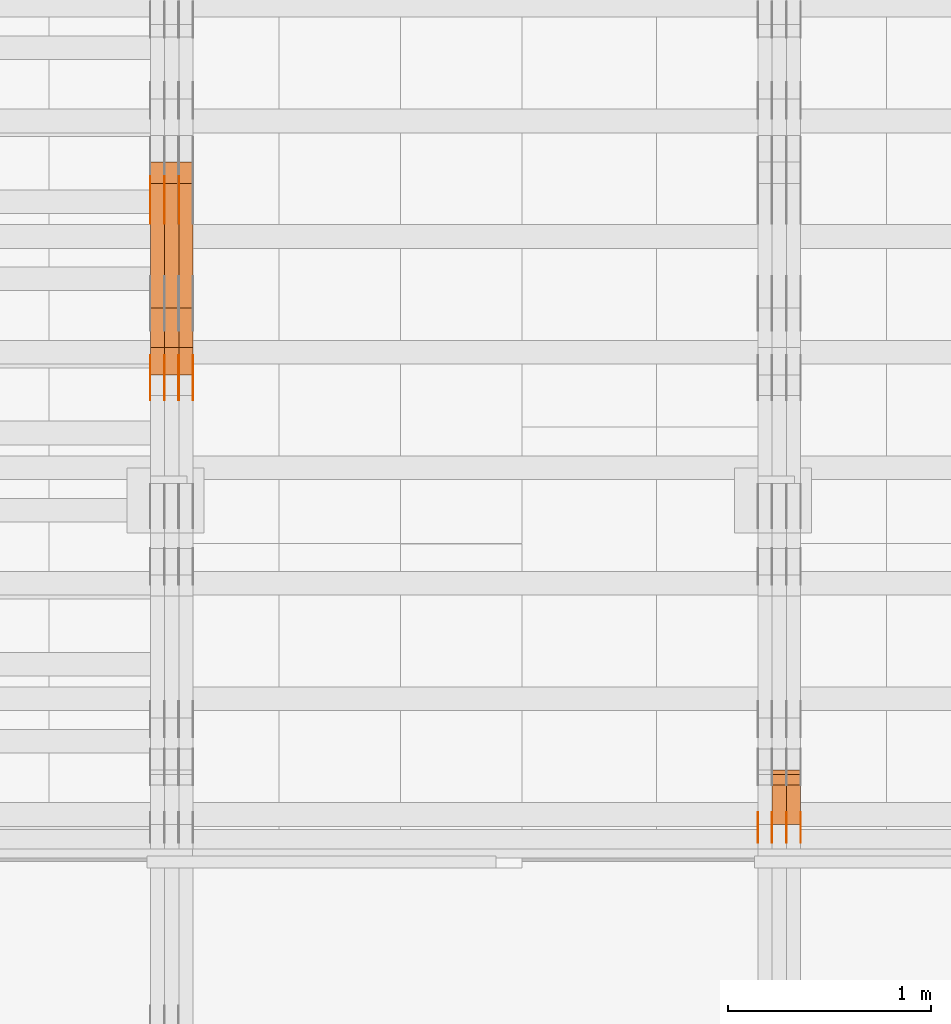
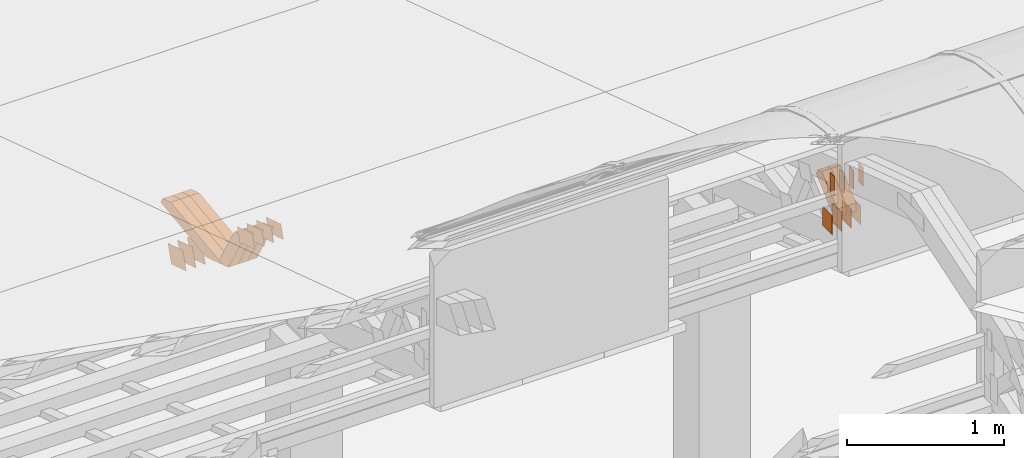
# One storey, part 87 of 385: 30 proxies.
"""IFC2X3 building model written with IfcOpenShell, lengths in millimetres."""

from ifc_helpers import new_model, entity, si_unit, converted_unit, derived_unit, direction, frame, origin, origin_2d_with_axis, place, context, subcontext, project, spatial, polyline, rectangle, outline, extrude, source, transform, mapped, material, type_object, type_shapes, element, save


model = new_model("IFC2X3")

# Units and contexts
model_context = context("Model", 3, precision=0.01, world=origin(), true_north=direction((6.12303176911189e-17, 1.0)))
body_context = subcontext(model_context, "Body", "Model", "MODEL_VIEW")
ifc_project = project(units=[si_unit("LENGTHUNIT", "METRE", prefix="MILLI"), si_unit("AREAUNIT", "SQUARE_METRE"), si_unit("VOLUMEUNIT", "CUBIC_METRE"), converted_unit("PLANEANGLEUNIT", "DEGREE", entity("IfcRatioMeasure", 0.0174532925199433), si_unit("PLANEANGLEUNIT", "RADIAN"), dimensions=[0, 0, 0, 0, 0, 0, 0]), si_unit("MASSUNIT", "GRAM", prefix="KILO"), derived_unit("MASSDENSITYUNIT", [(si_unit("MASSUNIT", "GRAM", prefix="KILO"), 1), (si_unit("LENGTHUNIT", "METRE"), -3)]), si_unit("TIMEUNIT", "SECOND"), si_unit("FREQUENCYUNIT", "HERTZ"), si_unit("THERMODYNAMICTEMPERATUREUNIT", "DEGREE_CELSIUS"), derived_unit("THERMALTRANSMITTANCEUNIT", [(si_unit("MASSUNIT", "GRAM", prefix="KILO"), 1), (si_unit("THERMODYNAMICTEMPERATUREUNIT", "KELVIN"), -1), (si_unit("TIMEUNIT", "SECOND"), -3)]), derived_unit("VOLUMETRICFLOWRATEUNIT", [(si_unit("LENGTHUNIT", "METRE"), 3), (si_unit("TIMEUNIT", "SECOND"), -1)]), si_unit("ELECTRICCURRENTUNIT", "AMPERE"), si_unit("ELECTRICVOLTAGEUNIT", "VOLT"), si_unit("POWERUNIT", "WATT"), si_unit("FORCEUNIT", "NEWTON", prefix="KILO"), si_unit("ILLUMINANCEUNIT", "LUX"), si_unit("LUMINOUSFLUXUNIT", "LUMEN"), si_unit("LUMINOUSINTENSITYUNIT", "CANDELA"), derived_unit("USERDEFINED", [(si_unit("MASSUNIT", "GRAM", prefix="KILO"), -1), (si_unit("LENGTHUNIT", "METRE"), -2), (si_unit("TIMEUNIT", "SECOND"), 3), (si_unit("LUMINOUSFLUXUNIT", "LUMEN"), 1)]), derived_unit("LINEARVELOCITYUNIT", [(si_unit("LENGTHUNIT", "METRE"), 1), (si_unit("TIMEUNIT", "SECOND"), -1)]), si_unit("PRESSUREUNIT", "PASCAL"), derived_unit("USERDEFINED", [(si_unit("LENGTHUNIT", "METRE"), -2), (si_unit("MASSUNIT", "GRAM", prefix="KILO"), 1), (si_unit("TIMEUNIT", "SECOND"), -2)])], contexts=[model_context])

# Site, building, storey
site_placement = place(None, origin())
site = spatial("IfcSite", under=ifc_project, at=site_placement, CompositionType="ELEMENT")
building_placement = place(site_placement, origin())
building = spatial("IfcBuilding", under=site, at=building_placement, CompositionType="ELEMENT")
storey_placement = place(building_placement, origin())
storey = spatial("IfcBuildingStorey", under=building, at=storey_placement, Name="Default", CompositionType="ELEMENT", Elevation=0.0)

# Proxies
ifc_material_1 = material(Name="IfcSurfaceStyle #102082")
building_element_proxy_type_1 = type_object("IfcBuildingElementProxyType", PredefinedType="NOTDEFINED", material=ifc_material_1)
shared_shape_1 = source(origin(), body_context, "Body", "SweptSolid", [
    extrude(rectangle(XDim=150.0, YDim=120.0, at=origin_2d_with_axis()), frame((75.0, 60.0, 0.0), z_axis=(0.0, 0.0, 1.0), x_axis=(-1.0, 0.0, 0.0)), (0.0, 0.0, 1.0), 1.3),
])
type_shapes(building_element_proxy_type_1, [shared_shape_1])
proxy_1_placement = place(building_placement, frame((6386.29999999999, 15840.0, 3652.70166015625), z_axis=(-1.0, 0.0, 0.0), x_axis=(0.0, 0.0, -1.0)))
element("IfcBuildingElementProxy", 1, at=proxy_1_placement, inside=storey, type_object=building_element_proxy_type_1, material=ifc_material_1, context=body_context, shape_type="MappedRepresentation", body=[
    mapped(shared_shape_1, transform((0.0, 0.0, 0.0), scale=1.0)),
])
ifc_material_2 = material(Name="IfcSurfaceStyle #102025")
building_element_proxy_type_2 = type_object("IfcBuildingElementProxyType", PredefinedType="NOTDEFINED", material=ifc_material_2)
shared_shape_2 = source(origin(), body_context, "Body", "SweptSolid", [
    extrude(rectangle(XDim=150.0, YDim=120.0, at=origin_2d_with_axis()), frame((75.0, 60.0, 0.0), z_axis=(0.0, 0.0, 1.0), x_axis=(-1.0, 0.0, 0.0)), (0.0, 0.0, 1.0), 1.3),
])
type_shapes(building_element_proxy_type_2, [shared_shape_2])
proxy_2_placement = place(building_placement, frame((6315.0, 15840.0, 3652.70166015625), z_axis=(-1.0, 0.0, 0.0), x_axis=(0.0, 0.0, -1.0)))
element("IfcBuildingElementProxy", 2, at=proxy_2_placement, inside=storey, type_object=building_element_proxy_type_2, material=ifc_material_2, context=body_context, shape_type="MappedRepresentation", body=[
    mapped(shared_shape_2, transform((0.0, 0.0, 0.0), scale=1.0)),
])
ifc_material_3 = material(Name="IfcSurfaceStyle #101968")
building_element_proxy_type_3 = type_object("IfcBuildingElementProxyType", PredefinedType="NOTDEFINED", material=ifc_material_3)
shared_shape_3 = source(origin(), body_context, "Body", "SweptSolid", [
    extrude(rectangle(XDim=150.0, YDim=120.0, at=origin_2d_with_axis()), frame((75.0, 60.0, 0.0), z_axis=(0.0, 0.0, 1.0), x_axis=(-1.0, 0.0, 0.0)), (0.0, 0.0, 1.0), 1.3),
])
type_shapes(building_element_proxy_type_3, [shared_shape_3])
proxy_3_placement = place(building_placement, frame((6316.29999999999, 15840.0, 3652.70166015625), z_axis=(-1.0, 0.0, 0.0), x_axis=(0.0, 0.0, -1.0)))
element("IfcBuildingElementProxy", 3, at=proxy_3_placement, inside=storey, type_object=building_element_proxy_type_3, material=ifc_material_3, context=body_context, shape_type="MappedRepresentation", body=[
    mapped(shared_shape_3, transform((0.0, 0.0, 0.0), scale=1.0)),
])
ifc_material_4 = material(Name="IfcSurfaceStyle #101911")
building_element_proxy_type_4 = type_object("IfcBuildingElementProxyType", PredefinedType="NOTDEFINED", material=ifc_material_4)
shared_shape_4 = source(origin(), body_context, "Body", "SweptSolid", [
    extrude(rectangle(XDim=150.0, YDim=120.0, at=origin_2d_with_axis()), frame((75.0, 60.0, 0.0), z_axis=(0.0, 0.0, 1.0), x_axis=(-1.0, 0.0, 0.0)), (0.0, 0.0, 1.0), 1.29999999999999),
])
type_shapes(building_element_proxy_type_4, [shared_shape_4])
proxy_4_placement = place(building_placement, frame((6245.0, 15840.0, 3652.70166015625), z_axis=(-1.0, 0.0, 0.0), x_axis=(0.0, 0.0, -1.0)))
element("IfcBuildingElementProxy", 4, at=proxy_4_placement, inside=storey, type_object=building_element_proxy_type_4, material=ifc_material_4, context=body_context, shape_type="MappedRepresentation", body=[
    mapped(shared_shape_4, transform((0.0, 0.0, 0.0), scale=1.0)),
])
ifc_material_5 = material(Name="IfcSurfaceStyle #101854")
building_element_proxy_type_5 = type_object("IfcBuildingElementProxyType", PredefinedType="NOTDEFINED", material=ifc_material_5)
shared_shape_5 = source(origin(), body_context, "Body", "SweptSolid", [
    extrude(rectangle(XDim=150.0, YDim=120.0, at=origin_2d_with_axis()), frame((75.0, 60.0, 0.0), z_axis=(0.0, 0.0, 1.0), x_axis=(-1.0, 0.0, 0.0)), (0.0, 0.0, 1.0), 1.29999999999999),
])
type_shapes(building_element_proxy_type_5, [shared_shape_5])
proxy_5_placement = place(building_placement, frame((6246.29999999999, 15840.0, 3652.70166015625), z_axis=(-1.0, 0.0, 0.0), x_axis=(0.0, 0.0, -1.0)))
element("IfcBuildingElementProxy", 5, at=proxy_5_placement, inside=storey, type_object=building_element_proxy_type_5, material=ifc_material_5, context=body_context, shape_type="MappedRepresentation", body=[
    mapped(shared_shape_5, transform((0.0, 0.0, 0.0), scale=1.0)),
])
ifc_material_6 = material(Name="IfcSurfaceStyle #101797")
building_element_proxy_type_6 = type_object("IfcBuildingElementProxyType", PredefinedType="NOTDEFINED", material=ifc_material_6)
shared_shape_6 = source(origin(), body_context, "Body", "SweptSolid", [
    extrude(rectangle(XDim=150.0, YDim=120.0, at=origin_2d_with_axis()), frame((75.0, 60.0, 0.0), z_axis=(0.0, 0.0, 1.0), x_axis=(-1.0, 0.0, 0.0)), (0.0, 0.0, 1.0), 1.29999999999999),
])
type_shapes(building_element_proxy_type_6, [shared_shape_6])
proxy_6_placement = place(building_placement, frame((6175.0, 15840.0, 3652.70166015625), z_axis=(-1.0, 0.0, 0.0), x_axis=(0.0, 0.0, -1.0)))
element("IfcBuildingElementProxy", 6, at=proxy_6_placement, inside=storey, type_object=building_element_proxy_type_6, material=ifc_material_6, context=body_context, shape_type="MappedRepresentation", body=[
    mapped(shared_shape_6, transform((0.0, 0.0, 0.0), scale=1.0)),
])
ifc_material_7 = material(Name="IfcSurfaceStyle #96610")
building_element_proxy_type_7 = type_object("IfcBuildingElementProxyType", PredefinedType="NOTDEFINED", material=ifc_material_7)
shared_shape_7 = source(origin(), body_context, "Body", "SweptSolid", [
    extrude(rectangle(XDim=150.0, YDim=60.0, at=origin_2d_with_axis()), frame((75.0000705696311, 30.0, 0.0), z_axis=(0.0, 0.0, 1.0), x_axis=(-1.0, 0.0, 0.0)), (0.0, 0.0, 1.0), 1.3),
])
type_shapes(building_element_proxy_type_7, [shared_shape_7])
proxy_7_placement = place(building_placement, frame((6386.29999999999, 15750.0, 3972.59919166338), z_axis=(-1.0, 0.0, 0.0), x_axis=(0.0, 0.0, -1.0)))
element("IfcBuildingElementProxy", 7, at=proxy_7_placement, inside=storey, type_object=building_element_proxy_type_7, material=ifc_material_7, context=body_context, shape_type="MappedRepresentation", body=[
    mapped(shared_shape_7, transform((0.0, 0.0, 0.0), scale=1.0)),
])
ifc_material_8 = material(Name="IfcSurfaceStyle #96553")
building_element_proxy_type_8 = type_object("IfcBuildingElementProxyType", PredefinedType="NOTDEFINED", material=ifc_material_8)
shared_shape_8 = source(origin(), body_context, "Body", "SweptSolid", [
    extrude(rectangle(XDim=150.0, YDim=60.0, at=origin_2d_with_axis()), frame((75.0000705696311, 30.0, 0.0), z_axis=(0.0, 0.0, 1.0), x_axis=(-1.0, 0.0, 0.0)), (0.0, 0.0, 1.0), 1.3),
])
type_shapes(building_element_proxy_type_8, [shared_shape_8])
proxy_8_placement = place(building_placement, frame((6315.0, 15750.0, 3972.59919166338), z_axis=(-1.0, 0.0, 0.0), x_axis=(0.0, 0.0, -1.0)))
element("IfcBuildingElementProxy", 8, at=proxy_8_placement, inside=storey, type_object=building_element_proxy_type_8, material=ifc_material_8, context=body_context, shape_type="MappedRepresentation", body=[
    mapped(shared_shape_8, transform((0.0, 0.0, 0.0), scale=1.0)),
])
ifc_material_9 = material(Name="IfcSurfaceStyle #96496")
building_element_proxy_type_9 = type_object("IfcBuildingElementProxyType", PredefinedType="NOTDEFINED", material=ifc_material_9)
shared_shape_9 = source(origin(), body_context, "Body", "SweptSolid", [
    extrude(rectangle(XDim=150.0, YDim=60.0, at=origin_2d_with_axis()), frame((75.0000705696311, 30.0, 0.0), z_axis=(0.0, 0.0, 1.0), x_axis=(-1.0, 0.0, 0.0)), (0.0, 0.0, 1.0), 1.3),
])
type_shapes(building_element_proxy_type_9, [shared_shape_9])
proxy_9_placement = place(building_placement, frame((6316.29999999999, 15750.0, 3972.59919166338), z_axis=(-1.0, 0.0, 0.0), x_axis=(0.0, 0.0, -1.0)))
element("IfcBuildingElementProxy", 9, at=proxy_9_placement, inside=storey, type_object=building_element_proxy_type_9, material=ifc_material_9, context=body_context, shape_type="MappedRepresentation", body=[
    mapped(shared_shape_9, transform((0.0, 0.0, 0.0), scale=1.0)),
])
ifc_material_10 = material(Name="IfcSurfaceStyle #96439")
building_element_proxy_type_10 = type_object("IfcBuildingElementProxyType", PredefinedType="NOTDEFINED", material=ifc_material_10)
shared_shape_10 = source(origin(), body_context, "Body", "SweptSolid", [
    extrude(rectangle(XDim=150.0, YDim=60.0, at=origin_2d_with_axis()), frame((75.0000705696311, 30.0, 0.0), z_axis=(0.0, 0.0, 1.0), x_axis=(-1.0, 0.0, 0.0)), (0.0, 0.0, 1.0), 1.29999999999999),
])
type_shapes(building_element_proxy_type_10, [shared_shape_10])
proxy_10_placement = place(building_placement, frame((6245.0, 15750.0, 3972.59919166338), z_axis=(-1.0, 0.0, 0.0), x_axis=(0.0, 0.0, -1.0)))
element("IfcBuildingElementProxy", 10, at=proxy_10_placement, inside=storey, type_object=building_element_proxy_type_10, material=ifc_material_10, context=body_context, shape_type="MappedRepresentation", body=[
    mapped(shared_shape_10, transform((0.0, 0.0, 0.0), scale=1.0)),
])
ifc_material_11 = material(Name="IfcSurfaceStyle #96382")
building_element_proxy_type_11 = type_object("IfcBuildingElementProxyType", PredefinedType="NOTDEFINED", material=ifc_material_11)
shared_shape_11 = source(origin(), body_context, "Body", "SweptSolid", [
    extrude(rectangle(XDim=150.0, YDim=60.0, at=origin_2d_with_axis()), frame((75.0000705696311, 30.0, 0.0), z_axis=(0.0, 0.0, 1.0), x_axis=(-1.0, 0.0, 0.0)), (0.0, 0.0, 1.0), 1.29999999999999),
])
type_shapes(building_element_proxy_type_11, [shared_shape_11])
proxy_11_placement = place(building_placement, frame((6246.29999999999, 15750.0, 3972.59919166338), z_axis=(-1.0, 0.0, 0.0), x_axis=(0.0, 0.0, -1.0)))
element("IfcBuildingElementProxy", 11, at=proxy_11_placement, inside=storey, type_object=building_element_proxy_type_11, material=ifc_material_11, context=body_context, shape_type="MappedRepresentation", body=[
    mapped(shared_shape_11, transform((0.0, 0.0, 0.0), scale=1.0)),
])
ifc_material_12 = material(Name="IfcSurfaceStyle #96325")
building_element_proxy_type_12 = type_object("IfcBuildingElementProxyType", PredefinedType="NOTDEFINED", material=ifc_material_12)
shared_shape_12 = source(origin(), body_context, "Body", "SweptSolid", [
    extrude(rectangle(XDim=150.0, YDim=60.0, at=origin_2d_with_axis()), frame((75.0000705696311, 30.0, 0.0), z_axis=(0.0, 0.0, 1.0), x_axis=(-1.0, 0.0, 0.0)), (0.0, 0.0, 1.0), 1.29999999999999),
])
type_shapes(building_element_proxy_type_12, [shared_shape_12])
proxy_12_placement = place(building_placement, frame((6175.0, 15750.0, 3972.59919166338), z_axis=(-1.0, 0.0, 0.0), x_axis=(0.0, 0.0, -1.0)))
element("IfcBuildingElementProxy", 12, at=proxy_12_placement, inside=storey, type_object=building_element_proxy_type_12, material=ifc_material_12, context=body_context, shape_type="MappedRepresentation", body=[
    mapped(shared_shape_12, transform((0.0, 0.0, 0.0), scale=1.0)),
])
ifc_material_13 = material(Name="IfcSurfaceStyle #87241")
building_element_proxy_type_13 = type_object("IfcBuildingElementProxyType", Name="T1-W50 87239", PredefinedType="NOTDEFINED", material=ifc_material_13)
shared_shape_13 = source(origin(), body_context, "Body", "SweptSolid", [
    extrude(outline(polyline([(-128.56619634284, -47.4999385885712), (133.151257249084, -47.4999385885712), (161.172800006526, -0.000129729183733609), (147.291467726413, 47.500068317755), (-142.513973767368, 47.500068317755), (-170.535354871815, -0.000129729183754689), (-128.56619634284, -47.4999385885712)])), frame((161.17310141218, 47.5001898716564, 0.0), z_axis=(0.0, 0.0, 1.0), x_axis=(-1.0, 0.0, 0.0)), (0.0, 0.0, 1.0), 70.0),
])
type_shapes(building_element_proxy_type_13, [shared_shape_13])
proxy_13_placement = place(building_placement, frame((6385.0, 16060.0297689714, 3761.73994820667), z_axis=(-1.0, 0.0, 0.0), x_axis=(0.0, -0.749388407538668, -0.662130662820156)))
element("IfcBuildingElementProxy", 13, at=proxy_13_placement, inside=storey, type_object=building_element_proxy_type_13, material=ifc_material_13, Name="T1-W50", context=body_context, shape_type="MappedRepresentation", body=[
    mapped(shared_shape_13, transform((0.0, 0.0, 0.0), scale=1.0)),
])
ifc_material_14 = material(Name="IfcSurfaceStyle #87166")
building_element_proxy_type_14 = type_object("IfcBuildingElementProxyType", Name="T1-W50 87164", PredefinedType="NOTDEFINED", material=ifc_material_14)
shared_shape_14 = source(origin(), body_context, "Body", "SweptSolid", [
    extrude(outline(polyline([(-128.56619634284, -47.4999385885712), (133.151257249084, -47.4999385885712), (161.172800006526, -0.000129729183733609), (147.291467726413, 47.500068317755), (-142.513973767368, 47.500068317755), (-170.535354871815, -0.000129729183754689), (-128.56619634284, -47.4999385885712)])), frame((161.17310141218, 47.5001898716564, 0.0), z_axis=(0.0, 0.0, 1.0), x_axis=(-1.0, 0.0, 0.0)), (0.0, 0.0, 1.0), 70.0),
])
type_shapes(building_element_proxy_type_14, [shared_shape_14])
proxy_14_placement = place(building_placement, frame((6315.0, 16060.0297689714, 3761.73994820667), z_axis=(-1.0, 0.0, 0.0), x_axis=(0.0, -0.749388407538668, -0.662130662820156)))
element("IfcBuildingElementProxy", 14, at=proxy_14_placement, inside=storey, type_object=building_element_proxy_type_14, material=ifc_material_14, Name="T1-W50", context=body_context, shape_type="MappedRepresentation", body=[
    mapped(shared_shape_14, transform((0.0, 0.0, 0.0), scale=1.0)),
])
ifc_material_15 = material(Name="IfcSurfaceStyle #65142")
building_element_proxy_type_15 = type_object("IfcBuildingElementProxyType", PredefinedType="NOTDEFINED", material=ifc_material_15)
shared_shape_15 = source(origin(), body_context, "Body", "SweptSolid", [
    extrude(outline(polyline([(-99.999796294464, -72.0000050220467), (99.9998768370438, -72.0000050220467), (100.000260677528, 72.0000050220467), (-100.000341220108, 72.0000050220467), (-99.999796294464, -72.0000050220467)])), frame((100.000260677528, 72.0000050220467, 0.0), z_axis=(0.0, 0.0, 1.0), x_axis=(-1.0, 0.0, 0.0)), (0.0, 0.0, 1.0), 1.3),
])
type_shapes(building_element_proxy_type_15, [shared_shape_15])
proxy_15_placement = place(building_placement, frame((3316.29999999999, 18936.3876569477, 2373.90613192527), z_axis=(-1.0, 0.0, 0.0), x_axis=(0.0, -0.951056516295124, 0.309016994375039)))
element("IfcBuildingElementProxy", 15, at=proxy_15_placement, inside=storey, type_object=building_element_proxy_type_15, material=ifc_material_15, context=body_context, shape_type="MappedRepresentation", body=[
    mapped(shared_shape_15, transform((0.0, 0.0, 0.0), scale=1.0)),
])
ifc_material_16 = material(Name="IfcSurfaceStyle #65085")
building_element_proxy_type_16 = type_object("IfcBuildingElementProxyType", PredefinedType="NOTDEFINED", material=ifc_material_16)
shared_shape_16 = source(origin(), body_context, "Body", "SweptSolid", [
    extrude(outline(polyline([(-99.999796294464, -72.0000050220467), (99.9998768370438, -72.0000050220467), (100.000260677528, 72.0000050220467), (-100.000341220108, 72.0000050220467), (-99.999796294464, -72.0000050220467)])), frame((100.000260677528, 72.0000050220467, 0.0), z_axis=(0.0, 0.0, 1.0), x_axis=(-1.0, 0.0, 0.0)), (0.0, 0.0, 1.0), 1.29999999999998),
])
type_shapes(building_element_proxy_type_16, [shared_shape_16])
proxy_16_placement = place(building_placement, frame((3245.0, 18936.3876569477, 2373.90613192527), z_axis=(-1.0, 0.0, 0.0), x_axis=(0.0, -0.951056516295124, 0.309016994375039)))
element("IfcBuildingElementProxy", 16, at=proxy_16_placement, inside=storey, type_object=building_element_proxy_type_16, material=ifc_material_16, context=body_context, shape_type="MappedRepresentation", body=[
    mapped(shared_shape_16, transform((0.0, 0.0, 0.0), scale=1.0)),
])
ifc_material_17 = material(Name="IfcSurfaceStyle #65028")
building_element_proxy_type_17 = type_object("IfcBuildingElementProxyType", PredefinedType="NOTDEFINED", material=ifc_material_17)
shared_shape_17 = source(origin(), body_context, "Body", "SweptSolid", [
    extrude(outline(polyline([(-99.999796294464, -72.0000050220467), (99.9998768370438, -72.0000050220467), (100.000260677528, 72.0000050220467), (-100.000341220108, 72.0000050220467), (-99.999796294464, -72.0000050220467)])), frame((100.000260677528, 72.0000050220467, 0.0), z_axis=(0.0, 0.0, 1.0), x_axis=(-1.0, 0.0, 0.0)), (0.0, 0.0, 1.0), 1.29999999999998),
])
type_shapes(building_element_proxy_type_17, [shared_shape_17])
proxy_17_placement = place(building_placement, frame((3246.29999999999, 18936.3876569477, 2373.90613192527), z_axis=(-1.0, 0.0, 0.0), x_axis=(0.0, -0.951056516295124, 0.309016994375039)))
element("IfcBuildingElementProxy", 17, at=proxy_17_placement, inside=storey, type_object=building_element_proxy_type_17, material=ifc_material_17, context=body_context, shape_type="MappedRepresentation", body=[
    mapped(shared_shape_17, transform((0.0, 0.0, 0.0), scale=1.0)),
])
ifc_material_18 = material(Name="IfcSurfaceStyle #64971")
building_element_proxy_type_18 = type_object("IfcBuildingElementProxyType", PredefinedType="NOTDEFINED", material=ifc_material_18)
shared_shape_18 = source(origin(), body_context, "Body", "SweptSolid", [
    extrude(outline(polyline([(-99.999796294464, -72.0000050220467), (99.9998768370438, -72.0000050220467), (100.000260677528, 72.0000050220467), (-100.000341220108, 72.0000050220467), (-99.999796294464, -72.0000050220467)])), frame((100.000260677528, 72.0000050220467, 0.0), z_axis=(0.0, 0.0, 1.0), x_axis=(-1.0, 0.0, 0.0)), (0.0, 0.0, 1.0), 1.29999999999999),
])
type_shapes(building_element_proxy_type_18, [shared_shape_18])
proxy_18_placement = place(building_placement, frame((3175.0, 18936.3876569477, 2373.90613192527), z_axis=(-1.0, 0.0, 0.0), x_axis=(0.0, -0.951056516295124, 0.309016994375039)))
element("IfcBuildingElementProxy", 18, at=proxy_18_placement, inside=storey, type_object=building_element_proxy_type_18, material=ifc_material_18, context=body_context, shape_type="MappedRepresentation", body=[
    mapped(shared_shape_18, transform((0.0, 0.0, 0.0), scale=1.0)),
])
ifc_material_19 = material(Name="IfcSurfaceStyle #60810")
building_element_proxy_type_19 = type_object("IfcBuildingElementProxyType", PredefinedType="NOTDEFINED", material=ifc_material_19)
shared_shape_19 = source(origin(), body_context, "Body", "SweptSolid", [
    extrude(outline(polyline([(-99.9999427841299, -54.0000599375792), (99.9996549037756, -54.0000599375792), (100.000407167194, 54.0000599375792), (-100.00011928684, 54.0000599375792), (-99.9999427841299, -54.0000599375792)])), frame((100.000407167194, 54.0000599375792, 0.0), z_axis=(0.0, 0.0, 1.0), x_axis=(-1.0, 0.0, 0.0)), (0.0, 0.0, 1.0), 1.3),
])
type_shapes(building_element_proxy_type_19, [shared_shape_19])
proxy_19_placement = place(building_placement, frame((3386.29999999999, 18065.0682492591, 3072.55239547302), z_axis=(-1.0, 0.0, 0.0), x_axis=(0.0, -0.951056516295154, 0.309016994374948)))
element("IfcBuildingElementProxy", 19, at=proxy_19_placement, inside=storey, type_object=building_element_proxy_type_19, material=ifc_material_19, context=body_context, shape_type="MappedRepresentation", body=[
    mapped(shared_shape_19, transform((0.0, 0.0, 0.0), scale=1.0)),
])
ifc_material_20 = material(Name="IfcSurfaceStyle #60753")
building_element_proxy_type_20 = type_object("IfcBuildingElementProxyType", PredefinedType="NOTDEFINED", material=ifc_material_20)
shared_shape_20 = source(origin(), body_context, "Body", "SweptSolid", [
    extrude(outline(polyline([(-99.9999427841299, -54.0000599375792), (99.9996549037756, -54.0000599375792), (100.000407167194, 54.0000599375792), (-100.00011928684, 54.0000599375792), (-99.9999427841299, -54.0000599375792)])), frame((100.000407167194, 54.0000599375792, 0.0), z_axis=(0.0, 0.0, 1.0), x_axis=(-1.0, 0.0, 0.0)), (0.0, 0.0, 1.0), 1.3),
])
type_shapes(building_element_proxy_type_20, [shared_shape_20])
proxy_20_placement = place(building_placement, frame((3315.0, 18065.0682492591, 3072.55239547302), z_axis=(-1.0, 0.0, 0.0), x_axis=(0.0, -0.951056516295154, 0.309016994374948)))
element("IfcBuildingElementProxy", 20, at=proxy_20_placement, inside=storey, type_object=building_element_proxy_type_20, material=ifc_material_20, context=body_context, shape_type="MappedRepresentation", body=[
    mapped(shared_shape_20, transform((0.0, 0.0, 0.0), scale=1.0)),
])
ifc_material_21 = material(Name="IfcSurfaceStyle #60696")
building_element_proxy_type_21 = type_object("IfcBuildingElementProxyType", PredefinedType="NOTDEFINED", material=ifc_material_21)
shared_shape_21 = source(origin(), body_context, "Body", "SweptSolid", [
    extrude(outline(polyline([(-99.9999427841299, -54.0000599375792), (99.9996549037756, -54.0000599375792), (100.000407167194, 54.0000599375792), (-100.00011928684, 54.0000599375792), (-99.9999427841299, -54.0000599375792)])), frame((100.000407167194, 54.0000599375792, 0.0), z_axis=(0.0, 0.0, 1.0), x_axis=(-1.0, 0.0, 0.0)), (0.0, 0.0, 1.0), 1.3),
])
type_shapes(building_element_proxy_type_21, [shared_shape_21])
proxy_21_placement = place(building_placement, frame((3316.29999999999, 18065.0682492591, 3072.55239547302), z_axis=(-1.0, 0.0, 0.0), x_axis=(0.0, -0.951056516295154, 0.309016994374948)))
element("IfcBuildingElementProxy", 21, at=proxy_21_placement, inside=storey, type_object=building_element_proxy_type_21, material=ifc_material_21, context=body_context, shape_type="MappedRepresentation", body=[
    mapped(shared_shape_21, transform((0.0, 0.0, 0.0), scale=1.0)),
])
ifc_material_22 = material(Name="IfcSurfaceStyle #60639")
building_element_proxy_type_22 = type_object("IfcBuildingElementProxyType", PredefinedType="NOTDEFINED", material=ifc_material_22)
shared_shape_22 = source(origin(), body_context, "Body", "SweptSolid", [
    extrude(outline(polyline([(-99.9999427841299, -54.0000599375792), (99.9996549037756, -54.0000599375792), (100.000407167194, 54.0000599375792), (-100.00011928684, 54.0000599375792), (-99.9999427841299, -54.0000599375792)])), frame((100.000407167194, 54.0000599375792, 0.0), z_axis=(0.0, 0.0, 1.0), x_axis=(-1.0, 0.0, 0.0)), (0.0, 0.0, 1.0), 1.29999999999998),
])
type_shapes(building_element_proxy_type_22, [shared_shape_22])
proxy_22_placement = place(building_placement, frame((3245.0, 18065.0682492591, 3072.55239547302), z_axis=(-1.0, 0.0, 0.0), x_axis=(0.0, -0.951056516295154, 0.309016994374948)))
element("IfcBuildingElementProxy", 22, at=proxy_22_placement, inside=storey, type_object=building_element_proxy_type_22, material=ifc_material_22, context=body_context, shape_type="MappedRepresentation", body=[
    mapped(shared_shape_22, transform((0.0, 0.0, 0.0), scale=1.0)),
])
ifc_material_23 = material(Name="IfcSurfaceStyle #60582")
building_element_proxy_type_23 = type_object("IfcBuildingElementProxyType", PredefinedType="NOTDEFINED", material=ifc_material_23)
shared_shape_23 = source(origin(), body_context, "Body", "SweptSolid", [
    extrude(outline(polyline([(-99.9999427841299, -54.0000599375792), (99.9996549037756, -54.0000599375792), (100.000407167194, 54.0000599375792), (-100.00011928684, 54.0000599375792), (-99.9999427841299, -54.0000599375792)])), frame((100.000407167194, 54.0000599375792, 0.0), z_axis=(0.0, 0.0, 1.0), x_axis=(-1.0, 0.0, 0.0)), (0.0, 0.0, 1.0), 1.29999999999998),
])
type_shapes(building_element_proxy_type_23, [shared_shape_23])
proxy_23_placement = place(building_placement, frame((3246.29999999999, 18065.0682492591, 3072.55239547302), z_axis=(-1.0, 0.0, 0.0), x_axis=(0.0, -0.951056516295154, 0.309016994374948)))
element("IfcBuildingElementProxy", 23, at=proxy_23_placement, inside=storey, type_object=building_element_proxy_type_23, material=ifc_material_23, context=body_context, shape_type="MappedRepresentation", body=[
    mapped(shared_shape_23, transform((0.0, 0.0, 0.0), scale=1.0)),
])
ifc_material_24 = material(Name="IfcSurfaceStyle #60525")
building_element_proxy_type_24 = type_object("IfcBuildingElementProxyType", PredefinedType="NOTDEFINED", material=ifc_material_24)
shared_shape_24 = source(origin(), body_context, "Body", "SweptSolid", [
    extrude(outline(polyline([(-99.9999427841299, -54.0000599375792), (99.9996549037756, -54.0000599375792), (100.000407167194, 54.0000599375792), (-100.00011928684, 54.0000599375792), (-99.9999427841299, -54.0000599375792)])), frame((100.000407167194, 54.0000599375792, 0.0), z_axis=(0.0, 0.0, 1.0), x_axis=(-1.0, 0.0, 0.0)), (0.0, 0.0, 1.0), 1.29999999999999),
])
type_shapes(building_element_proxy_type_24, [shared_shape_24])
proxy_24_placement = place(building_placement, frame((3175.0, 18065.0682492591, 3072.55239547302), z_axis=(-1.0, 0.0, 0.0), x_axis=(0.0, -0.951056516295154, 0.309016994374948)))
element("IfcBuildingElementProxy", 24, at=proxy_24_placement, inside=storey, type_object=building_element_proxy_type_24, material=ifc_material_24, context=body_context, shape_type="MappedRepresentation", body=[
    mapped(shared_shape_24, transform((0.0, 0.0, 0.0), scale=1.0)),
])
ifc_material_25 = material(Name="IfcSurfaceStyle #50658")
building_element_proxy_type_25 = type_object("IfcBuildingElementProxyType", Name="T1-W35 50656", PredefinedType="NOTDEFINED", material=ifc_material_25)
shared_shape_25 = source(origin(), body_context, "Body", "SweptSolid", [
    extrude(outline(polyline([(-196.877231354918, -47.499850828051), (197.289756738813, -47.499850828051), (177.380838136073, -0.000131002767018074), (124.615181369032, 47.4999163294346), (-302.408544889, 47.4999163294346), (-196.877231354918, -47.499850828051)])), frame((197.289756738813, 47.5002438363521, 0.0), z_axis=(0.0, 0.0, 1.0), x_axis=(-1.0, 0.0, 0.0)), (0.0, 0.0, 1.0), 70.0),
])
type_shapes(building_element_proxy_type_25, [shared_shape_25])
proxy_25_placement = place(building_placement, frame((3385.0, 18249.5528960018, 2724.16980022534), z_axis=(-1.0, 0.0, 0.0), x_axis=(0.0, -0.5, 0.866025403784439)))
element("IfcBuildingElementProxy", 25, at=proxy_25_placement, inside=storey, type_object=building_element_proxy_type_25, material=ifc_material_25, Name="T1-W35", context=body_context, shape_type="MappedRepresentation", body=[
    mapped(shared_shape_25, transform((0.0, 0.0, 0.0), scale=1.0)),
])
ifc_material_26 = material(Name="IfcSurfaceStyle #50592")
building_element_proxy_type_26 = type_object("IfcBuildingElementProxyType", Name="T1-W35 50590", PredefinedType="NOTDEFINED", material=ifc_material_26)
shared_shape_26 = source(origin(), body_context, "Body", "SweptSolid", [
    extrude(outline(polyline([(-196.877231354918, -47.499850828051), (197.289756738813, -47.499850828051), (177.380838136073, -0.000131002767018074), (124.615181369032, 47.4999163294346), (-302.408544889, 47.4999163294346), (-196.877231354918, -47.499850828051)])), frame((197.289756738813, 47.5002438363521, 0.0), z_axis=(0.0, 0.0, 1.0), x_axis=(-1.0, 0.0, 0.0)), (0.0, 0.0, 1.0), 70.0),
])
type_shapes(building_element_proxy_type_26, [shared_shape_26])
proxy_26_placement = place(building_placement, frame((3315.0, 18249.5528960018, 2724.16980022534), z_axis=(-1.0, 0.0, 0.0), x_axis=(0.0, -0.5, 0.866025403784439)))
element("IfcBuildingElementProxy", 26, at=proxy_26_placement, inside=storey, type_object=building_element_proxy_type_26, material=ifc_material_26, Name="T1-W35", context=body_context, shape_type="MappedRepresentation", body=[
    mapped(shared_shape_26, transform((0.0, 0.0, 0.0), scale=1.0)),
])
ifc_material_27 = material(Name="IfcSurfaceStyle #50526")
building_element_proxy_type_27 = type_object("IfcBuildingElementProxyType", Name="T1-W35 50524", PredefinedType="NOTDEFINED", material=ifc_material_27)
shared_shape_27 = source(origin(), body_context, "Body", "SweptSolid", [
    extrude(outline(polyline([(-196.877231354918, -47.499850828051), (197.289756738813, -47.499850828051), (177.380838136073, -0.000131002767018074), (124.615181369032, 47.4999163294346), (-302.408544889, 47.4999163294346), (-196.877231354918, -47.499850828051)])), frame((197.289756738813, 47.5002438363521, 0.0), z_axis=(0.0, 0.0, 1.0), x_axis=(-1.0, 0.0, 0.0)), (0.0, 0.0, 1.0), 70.0),
])
type_shapes(building_element_proxy_type_27, [shared_shape_27])
proxy_27_placement = place(building_placement, frame((3245.0, 18249.5528960018, 2724.16980022534), z_axis=(-1.0, 0.0, 0.0), x_axis=(0.0, -0.5, 0.866025403784439)))
element("IfcBuildingElementProxy", 27, at=proxy_27_placement, inside=storey, type_object=building_element_proxy_type_27, material=ifc_material_27, Name="T1-W35", context=body_context, shape_type="MappedRepresentation", body=[
    mapped(shared_shape_27, transform((0.0, 0.0, 0.0), scale=1.0)),
])
ifc_material_28 = material(Name="IfcSurfaceStyle #50262")
building_element_proxy_type_28 = type_object("IfcBuildingElementProxyType", Name="T1-W6 50260", PredefinedType="NOTDEFINED", material=ifc_material_28)
shared_shape_28 = source(origin(), body_context, "Body", "SweptSolid", [
    extrude(outline(polyline([(-485.945461934772, -47.500204767976), (183.41906495488, -47.500204767976), (284.061400026172, 0.000179660053988773), (303.127757064591, 47.500114937949), (-284.66276011087, 47.500114937949), (-485.945461934772, -47.500204767976)])), frame((303.127970456024, 47.5001450766485, 0.0), z_axis=(0.0, 0.0, 1.0), x_axis=(-1.0, 0.0, 0.0)), (0.0, 0.0, 1.0), 70.0),
])
type_shapes(building_element_proxy_type_28, [shared_shape_28])
proxy_28_placement = place(building_placement, frame((3385.0, 19075.4826373647, 2770.72729201433), z_axis=(-1.0, 0.0, 0.0), x_axis=(0.0, -0.991969529622927, -0.126477082112413)))
element("IfcBuildingElementProxy", 28, at=proxy_28_placement, inside=storey, type_object=building_element_proxy_type_28, material=ifc_material_28, Name="T1-W6", context=body_context, shape_type="MappedRepresentation", body=[
    mapped(shared_shape_28, transform((0.0, 0.0, 0.0), scale=1.0)),
])
ifc_material_29 = material(Name="IfcSurfaceStyle #50196")
building_element_proxy_type_29 = type_object("IfcBuildingElementProxyType", Name="T1-W6 50194", PredefinedType="NOTDEFINED", material=ifc_material_29)
shared_shape_29 = source(origin(), body_context, "Body", "SweptSolid", [
    extrude(outline(polyline([(-485.945461934772, -47.500204767976), (183.41906495488, -47.500204767976), (284.061400026172, 0.000179660053988773), (303.127757064591, 47.500114937949), (-284.66276011087, 47.500114937949), (-485.945461934772, -47.500204767976)])), frame((303.127970456024, 47.5001450766485, 0.0), z_axis=(0.0, 0.0, 1.0), x_axis=(-1.0, 0.0, 0.0)), (0.0, 0.0, 1.0), 70.0),
])
type_shapes(building_element_proxy_type_29, [shared_shape_29])
proxy_29_placement = place(building_placement, frame((3315.0, 19075.4826373647, 2770.72729201433), z_axis=(-1.0, 0.0, 0.0), x_axis=(0.0, -0.991969529622927, -0.126477082112413)))
element("IfcBuildingElementProxy", 29, at=proxy_29_placement, inside=storey, type_object=building_element_proxy_type_29, material=ifc_material_29, Name="T1-W6", context=body_context, shape_type="MappedRepresentation", body=[
    mapped(shared_shape_29, transform((0.0, 0.0, 0.0), scale=1.0)),
])
ifc_material_30 = material(Name="IfcSurfaceStyle #50130")
building_element_proxy_type_30 = type_object("IfcBuildingElementProxyType", Name="T1-W6 50128", PredefinedType="NOTDEFINED", material=ifc_material_30)
shared_shape_30 = source(origin(), body_context, "Body", "SweptSolid", [
    extrude(outline(polyline([(-485.945461934772, -47.500204767976), (183.41906495488, -47.500204767976), (284.061400026172, 0.000179660053988773), (303.127757064591, 47.500114937949), (-284.66276011087, 47.500114937949), (-485.945461934772, -47.500204767976)])), frame((303.127970456024, 47.5001450766485, 0.0), z_axis=(0.0, 0.0, 1.0), x_axis=(-1.0, 0.0, 0.0)), (0.0, 0.0, 1.0), 70.0),
])
type_shapes(building_element_proxy_type_30, [shared_shape_30])
proxy_30_placement = place(building_placement, frame((3245.0, 19075.4826373647, 2770.72729201433), z_axis=(-1.0, 0.0, 0.0), x_axis=(0.0, -0.991969529622927, -0.126477082112413)))
element("IfcBuildingElementProxy", 30, at=proxy_30_placement, inside=storey, type_object=building_element_proxy_type_30, material=ifc_material_30, Name="T1-W6", context=body_context, shape_type="MappedRepresentation", body=[
    mapped(shared_shape_30, transform((0.0, 0.0, 0.0), scale=1.0)),
])

save(model, "model.ifc")
